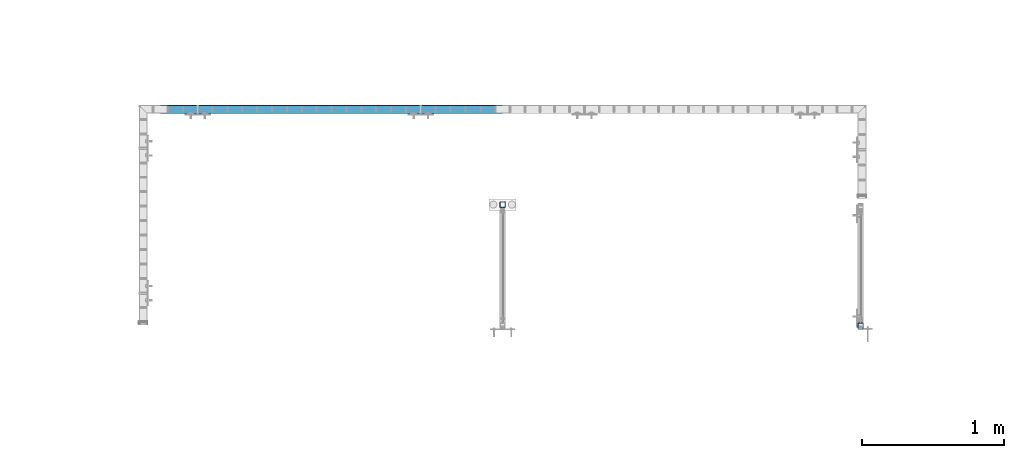
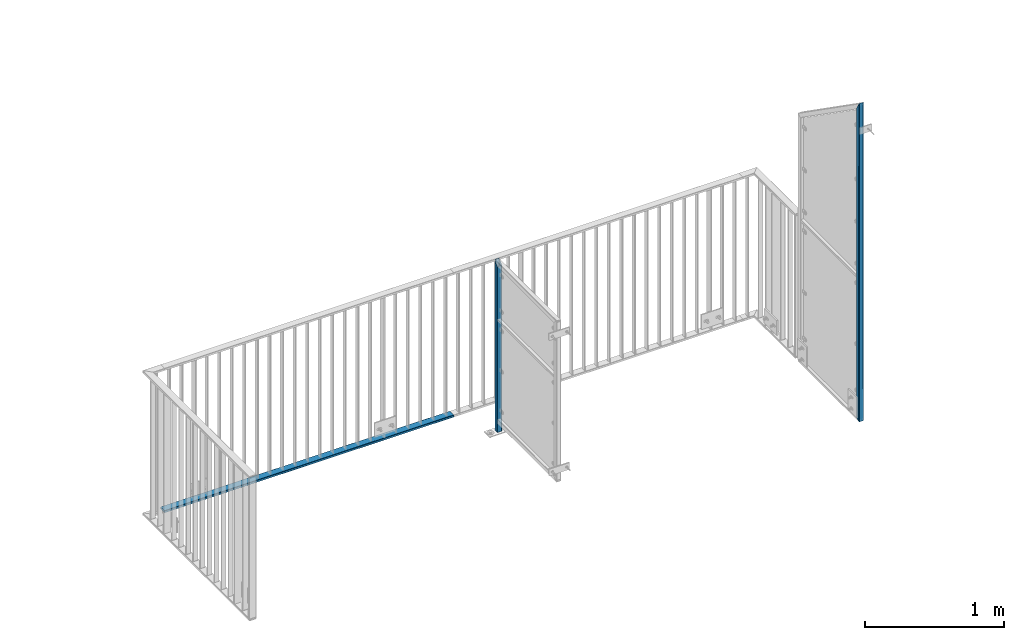
# One storey, part 26 of 156: 3 beams, 3 elements without a shape of their own.
"""IFC2X3 building model written with IfcOpenShell, lengths in millimetres."""

from ifc_helpers import new_model, si_unit, frame, origin_with_axes, origin_2d_with_axis, place, context, subcontext, project, spatial, hollow_rectangle, extrude, clip, halfspace, material, type_object, element, aggregate, save


model = new_model("IFC2X3")

# Units and contexts
model_context = context("Model", 3, precision=1e-05, world=origin_with_axes())
body_context = subcontext(model_context, "Body", "Model", "MODEL_VIEW")
ifc_project = project(units=[si_unit("LENGTHUNIT", "METRE", prefix="MILLI"), si_unit("AREAUNIT", "SQUARE_METRE"), si_unit("VOLUMEUNIT", "CUBIC_METRE"), si_unit("MASSUNIT", "GRAM", prefix="KILO"), si_unit("TIMEUNIT", "SECOND"), si_unit("PLANEANGLEUNIT", "RADIAN"), si_unit("SOLIDANGLEUNIT", "STERADIAN"), si_unit("THERMODYNAMICTEMPERATUREUNIT", "DEGREE_CELSIUS"), si_unit("LUMINOUSINTENSITYUNIT", "LUMEN")], contexts=[model_context])

# Site, building, storey
site_placement = place(None, origin_with_axes())
site = spatial("IfcSite", under=ifc_project, at=site_placement, CompositionType="ELEMENT")
building_placement = place(site_placement, origin_with_axes())
building = spatial("IfcBuilding", under=site, at=building_placement, Name="Undefined", CompositionType="ELEMENT")
storey_placement = place(building_placement, origin_with_axes())
storey = spatial("IfcBuildingStorey", under=building, at=storey_placement, Name="Undefined", CompositionType="ELEMENT", Elevation=0.0)

# Assembly, beam
assembly_1_placement = place(storey_placement, origin_with_axes())
assembly_1 = element("IfcElementAssembly", 1, at=assembly_1_placement, inside=storey, AssemblyPlace="NOTDEFINED", PredefinedType="RIGID_FRAME")
ifc_material = material(Name="STEEL/S235JR")
beam_type_1 = type_object("IfcBeamType", Name="K60/20/2", PredefinedType="NOTDEFINED")
beam_1_placement = place(assembly_1_placement, frame((33999.9535961914, 21657.9919947282, 2740.0), z_axis=(0.0, -1.0, 0.0), x_axis=(-1.0, 0.0, 0.0)))
beam_1 = element("IfcBeam", 2, at=beam_1_placement, type_object=beam_type_1, material=ifc_material, ObjectType="K60/20/2", context=body_context, shape_type="SweptSolid", body=[
    extrude(hollow_rectangle(XDim=20.0, YDim=60.0, WallThickness=2.0, InnerFilletRadius=2.0, OuterFilletRadius=4.0, at=origin_2d_with_axis()), frame((2402.81, 0.0, 0.0), z_axis=(-1.0, 0.0, 0.0), x_axis=(0.0, -1.0, 0.0)), (0.0, 0.0, 1.0), 2402.81),
])
aggregate(assembly_1, [beam_1])

assembly_2_placement = place(storey_placement, origin_with_axes())
assembly_2 = element("IfcElementAssembly", 3, at=assembly_2_placement, inside=storey, AssemblyPlace="NOTDEFINED", PredefinedType="RIGID_FRAME")
beam_type_2 = type_object("IfcBeamType", Name="K40/3", PredefinedType="NOTDEFINED")
beam_2_placement = place(assembly_2_placement, frame((34000.0, 20988.0029605892, 4299.99608012897), z_axis=(1.0, 0.0, 0.0), x_axis=(0.0, 0.000195990999960296, -0.999999980793764)))
beam_2 = element("IfcBeam", 4, at=beam_2_placement, type_object=beam_type_2, material=ifc_material, ObjectType="K40/3", context=body_context, shape_type="Clipping", body=[
    clip(clip(extrude(hollow_rectangle(XDim=40.0, YDim=40.0, WallThickness=3.0, InnerFilletRadius=3.0, OuterFilletRadius=6.0, at=origin_2d_with_axis()), frame((1317.21220694614, 0.0, 0.0), z_axis=(-1.0, 0.0, 0.0), x_axis=(0.0, -1.0, 0.0)), (0.0, 0.0, 1.0), 1517.43), halfspace(frame((1297.00033107046, -3.63797880709171e-12, -20.0), z_axis=(-1.0, 0.0, 0.0), x_axis=(0.0, 1.0, 0.0)), True)), halfspace(frame((-200.000003844783, 19.9999999999418, 0.0), z_axis=(0.707176071357089, 0.70703748422552, 0.0), x_axis=(0.0, 0.0, -1.0)), True)),
])
aggregate(assembly_2, [beam_2])

assembly_3_placement = place(storey_placement, origin_with_axes())
assembly_3 = element("IfcElementAssembly", 5, at=assembly_3_placement, inside=storey, AssemblyPlace="NOTDEFINED", PredefinedType="RIGID_FRAME")
beam_3_placement = place(assembly_3_placement, frame((36514.9961242676, 20138.0037231445, 5505.42577206617), z_axis=(1.0, 0.0, 0.0), x_axis=(0.0, 0.0, -1.0)))
beam_3 = element("IfcBeam", 6, at=beam_3_placement, type_object=beam_type_2, material=ifc_material, ObjectType="K40/3", context=body_context, shape_type="Clipping", body=[
    clip(clip(extrude(hollow_rectangle(XDim=40.0, YDim=40.0, WallThickness=3.0, InnerFilletRadius=3.0, OuterFilletRadius=6.0, at=origin_2d_with_axis()), frame((2814.3296158744, 0.0, 0.0), z_axis=(-1.0, 0.0, 0.0), x_axis=(0.0, -1.0, 0.0)), (0.0, 0.0, 1.0), 2848.92), halfspace(frame((2775.42577206617, -20.0, 0.0), z_axis=(0.894427191199917, 0.447213595099955, 0.0), x_axis=(0.0, 0.0, 1.0)), False)), halfspace(frame((-24.1088462508069, -20.0, 0.0), z_axis=(-0.461748567887819, 0.887010856784486, 0.0), x_axis=(0.0, 0.0, -1.0)), False)),
])
aggregate(assembly_3, [beam_3])

save(model, "model.ifc")
